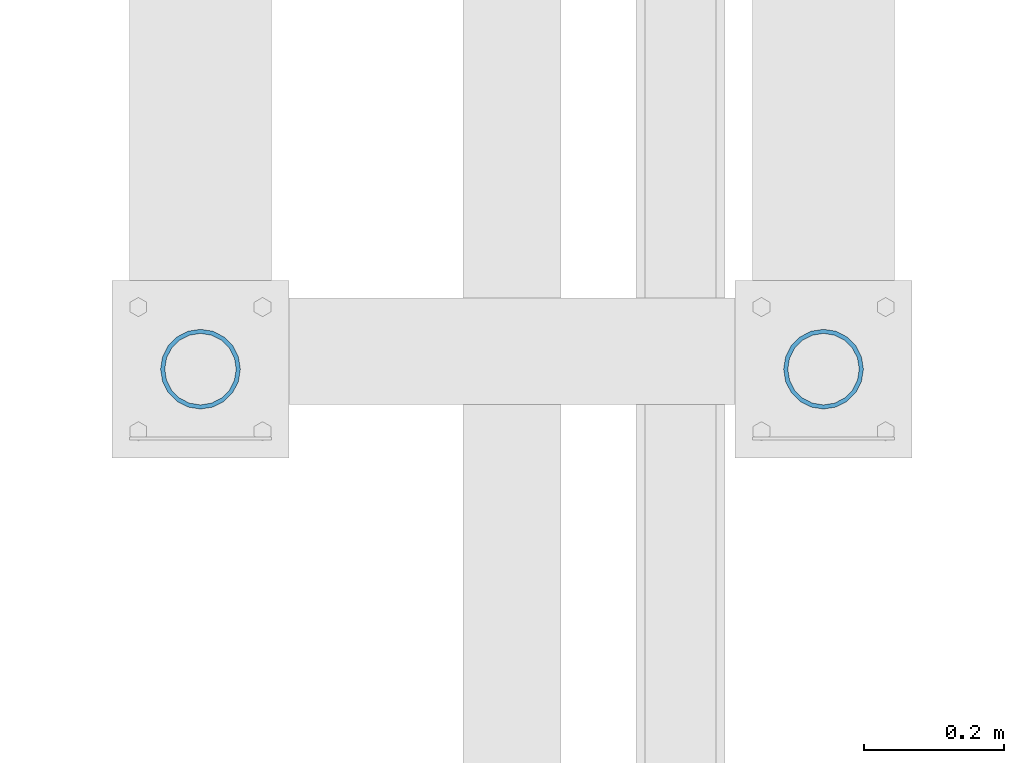
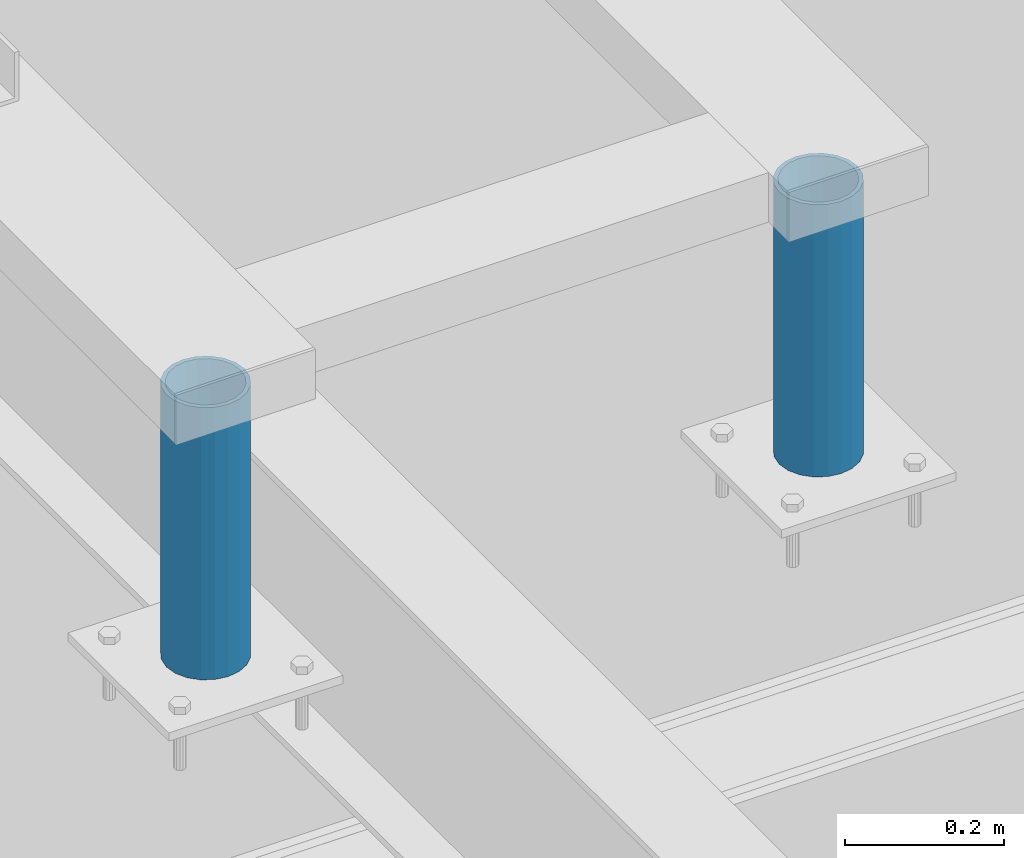
# One storey, part 560 of 1179: 2 columns, 1 element without a shape of its own.
"""IFC2X3 building model written with IfcOpenShell, lengths in millimetres."""

from ifc_helpers import new_model, si_unit, frame, origin_with_axes, place, context, subcontext, project, spatial, faceted_brep, material, type_object, element, aggregate, save


model = new_model("IFC2X3")

# Units and contexts
model_context = context("Model", 3, precision=1e-05, world=origin_with_axes())
body_context = subcontext(model_context, "Body", "Model", "MODEL_VIEW")
ifc_project = project(units=[si_unit("LENGTHUNIT", "METRE", prefix="MILLI"), si_unit("AREAUNIT", "SQUARE_METRE"), si_unit("VOLUMEUNIT", "CUBIC_METRE"), si_unit("MASSUNIT", "GRAM", prefix="KILO"), si_unit("TIMEUNIT", "SECOND"), si_unit("PLANEANGLEUNIT", "RADIAN"), si_unit("SOLIDANGLEUNIT", "STERADIAN"), si_unit("THERMODYNAMICTEMPERATUREUNIT", "DEGREE_CELSIUS"), si_unit("LUMINOUSINTENSITYUNIT", "LUMEN")], contexts=[model_context])

# Site, building, storey
site_placement = place(None, origin_with_axes())
site = spatial("IfcSite", under=ifc_project, at=site_placement, CompositionType="ELEMENT")
building_placement = place(site_placement, origin_with_axes())
building = spatial("IfcBuilding", under=site, at=building_placement, Name="Undefined", CompositionType="ELEMENT")
storey_placement = place(building_placement, origin_with_axes())
storey = spatial("IfcBuildingStorey", under=building, at=storey_placement, Name="Undefined", CompositionType="ELEMENT", Elevation=0.0)

# Assembly, columns
assembly_placement = place(storey_placement, origin_with_axes())
assembly = element("IfcElementAssembly", 1, at=assembly_placement, inside=storey, Name="FRAME", AssemblyPlace="NOTDEFINED", PredefinedType="RIGID_FRAME")
ifc_material = material()
column_type = type_object("IfcColumnType", Name="PIPE4SCH40", PredefinedType="NOTDEFINED")
column_1_placement = place(assembly_placement, frame((20575.5875, 36227.6225542222, 13265.15), z_axis=(0.0, 1.0, 0.0), x_axis=(0.0, 0.0, 1.0)))
column_1 = element("IfcColumn", 2, at=column_1_placement, type_object=column_type, material=ifc_material, Name="COLUMN", ObjectType="PIPE4SCH40", context=body_context, shape_type="Brep", body=[
    faceted_brep([(0.0, -51.1301999999996, 0.0), (0.0, -48.6277098894752, 15.8001007257917), (419.099999999999, -48.6277098894752, 15.8001007257917), (419.099999999999, -51.1301999999996, 0.0), (0.0, -41.3652007257915, 30.0535775067619), (419.099999999999, -41.3652007257915, 30.0535775067619), (0.0, -30.0535775067656, 41.3652007257915), (419.099999999999, -30.0535775067656, 41.3652007257915), (0.0, -15.8001007257917, 48.6277098894716), (419.099999999999, -15.8001007257917, 48.6277098894716), (0.0, 0.0, 51.1301999999996), (419.099999999999, 0.0, 51.1301999999996), (0.0, 15.8001007257917, 48.6277098894716), (419.099999999999, 15.8001007257917, 48.6277098894716), (0.0, 30.0535775067656, 41.3652007257915), (419.099999999999, 30.0535775067656, 41.3652007257915), (0.0, 41.3652007257915, 30.0535775067619), (419.099999999999, 41.3652007257915, 30.0535775067619), (0.0, 48.6277098894752, 15.8001007257917), (419.099999999999, 48.6277098894752, 15.8001007257917), (0.0, 51.1301999999996, 0.0), (419.099999999999, 51.1301999999996, 0.0), (0.0, 48.6277098894752, -15.8001007257917), (419.099999999999, 48.6277098894752, -15.8001007257917), (0.0, 41.3652007257915, -30.0535775067619), (419.099999999999, 41.3652007257915, -30.0535775067619), (0.0, 30.0535775067656, -41.3652007257915), (419.099999999999, 30.0535775067656, -41.3652007257915), (0.0, 15.8001007257917, -48.6277098894716), (419.099999999999, 15.8001007257917, -48.6277098894716), (0.0, 0.0, -51.1301999999996), (419.099999999999, 0.0, -51.1301999999996), (0.0, -15.8001007257917, -48.6277098894716), (419.099999999999, -15.8001007257917, -48.6277098894716), (0.0, -30.0535775067656, -41.3652007257915), (419.099999999999, -30.0535775067656, -41.3652007257915), (0.0, -41.3652007257915, -30.0535775067619), (419.099999999999, -41.3652007257915, -30.0535775067619), (0.0, -48.6277098894752, -15.8001007257917), (419.099999999999, -48.6277098894752, -15.8001007257917), (0.0, -57.1500000000015, 0.0), (0.0, -54.3528799062697, -17.6603212285263), (419.099999999999, -54.3528799062697, -17.6603212285263), (419.099999999999, -57.1500000000015, 0.0), (0.0, -46.235321228527, -33.5919271685125), (419.099999999999, -46.235321228527, -33.5919271685125), (0.0, -33.5919271685161, -46.2353212285307), (419.099999999999, -33.5919271685161, -46.2353212285307), (0.0, -17.6603212285299, -54.3528799062697), (419.099999999999, -17.6603212285299, -54.3528799062697), (0.0, 0.0, -57.1500000000015), (419.099999999999, 0.0, -57.1500000000015), (0.0, 17.6603212285299, -54.3528799062697), (419.099999999999, 17.6603212285299, -54.3528799062697), (0.0, 33.5919271685161, -46.2353212285307), (419.099999999999, 33.5919271685161, -46.2353212285307), (0.0, 46.235321228527, -33.5919271685125), (419.099999999999, 46.235321228527, -33.5919271685125), (0.0, 54.3528799062697, -17.6603212285263), (419.099999999999, 54.3528799062697, -17.6603212285263), (0.0, 57.1500000000015, 0.0), (419.099999999999, 57.1500000000015, 0.0), (0.0, 54.3528799062697, 17.6603212285263), (419.099999999999, 54.3528799062697, 17.6603212285263), (0.0, 46.235321228527, 33.5919271685125), (419.099999999999, 46.235321228527, 33.5919271685125), (0.0, 33.5919271685161, 46.2353212285307), (419.099999999999, 33.5919271685161, 46.2353212285307), (0.0, 17.6603212285299, 54.3528799062697), (419.099999999999, 17.6603212285299, 54.3528799062697), (0.0, 0.0, 57.1500000000015), (419.099999999999, 0.0, 57.1500000000015), (0.0, -17.6603212285299, 54.3528799062697), (419.099999999999, -17.6603212285299, 54.3528799062697), (0.0, -33.5919271685161, 46.2353212285307), (419.099999999999, -33.5919271685161, 46.2353212285307), (0.0, -46.235321228527, 33.5919271685125), (419.099999999999, -46.235321228527, 33.5919271685125), (0.0, -54.3528799062697, 17.6603212285263), (419.099999999999, -54.3528799062697, 17.6603212285263)], [[[0, 1, 2, 3]], [[1, 4, 5, 2]], [[4, 6, 7, 5]], [[6, 8, 9, 7]], [[8, 10, 11, 9]], [[10, 12, 13, 11]], [[12, 14, 15, 13]], [[14, 16, 17, 15]], [[16, 18, 19, 17]], [[18, 20, 21, 19]], [[20, 22, 23, 21]], [[22, 24, 25, 23]], [[24, 26, 27, 25]], [[26, 28, 29, 27]], [[28, 30, 31, 29]], [[30, 32, 33, 31]], [[32, 34, 35, 33]], [[34, 36, 37, 35]], [[36, 38, 39, 37]], [[38, 0, 3, 39]], [[40, 41, 42, 43]], [[41, 44, 45, 42]], [[44, 46, 47, 45]], [[46, 48, 49, 47]], [[48, 50, 51, 49]], [[50, 52, 53, 51]], [[52, 54, 55, 53]], [[54, 56, 57, 55]], [[56, 58, 59, 57]], [[58, 60, 61, 59]], [[60, 62, 63, 61]], [[62, 64, 65, 63]], [[64, 66, 67, 65]], [[66, 68, 69, 67]], [[68, 70, 71, 69]], [[70, 72, 73, 71]], [[72, 74, 75, 73]], [[74, 76, 77, 75]], [[76, 78, 79, 77]], [[78, 40, 43, 79]], [[45, 47, 49, 51, 53, 55, 57, 59, 61, 63, 65, 67, 69, 71, 73, 75, 77, 79, 43, 42], [5, 7, 9, 11, 13, 15, 17, 19, 21, 23, 25, 27, 29, 31, 33, 35, 37, 39, 3, 2]], [[78, 76, 74, 72, 70, 68, 66, 64, 62, 60, 58, 56, 54, 52, 50, 48, 46, 44, 41, 40], [38, 36, 34, 32, 30, 28, 26, 24, 22, 20, 18, 16, 14, 12, 10, 8, 6, 4, 1, 0]]]),
])
column_2_placement = place(assembly_placement, frame((19683.4125, 36227.6225542222, 13265.15), z_axis=(0.0, 1.0, 0.0), x_axis=(0.0, 0.0, 1.0)))
column_2 = element("IfcColumn", 3, at=column_2_placement, type_object=column_type, material=ifc_material, Name="COLUMN", ObjectType="PIPE4SCH40", context=body_context, shape_type="Brep", body=[
    faceted_brep([(0.0, -51.1301999999996, 0.0), (0.0, -48.6277098894752, 15.8001007257917), (419.099999999999, -48.6277098894752, 15.8001007257917), (419.099999999999, -51.1301999999996, 0.0), (0.0, -41.3652007257915, 30.0535775067619), (419.099999999999, -41.3652007257915, 30.0535775067619), (0.0, -30.0535775067656, 41.3652007257915), (419.099999999999, -30.0535775067656, 41.3652007257915), (0.0, -15.8001007257917, 48.6277098894716), (419.099999999999, -15.8001007257917, 48.6277098894716), (0.0, 0.0, 51.1301999999996), (419.099999999999, 0.0, 51.1301999999996), (0.0, 15.8001007257917, 48.6277098894716), (419.099999999999, 15.8001007257917, 48.6277098894716), (0.0, 30.0535775067656, 41.3652007257915), (419.099999999999, 30.0535775067656, 41.3652007257915), (0.0, 41.3652007257915, 30.0535775067619), (419.099999999999, 41.3652007257915, 30.0535775067619), (0.0, 48.6277098894752, 15.8001007257917), (419.099999999999, 48.6277098894752, 15.8001007257917), (0.0, 51.1301999999996, 0.0), (419.099999999999, 51.1301999999996, 0.0), (0.0, 48.6277098894752, -15.8001007257917), (419.099999999999, 48.6277098894752, -15.8001007257917), (0.0, 41.3652007257915, -30.0535775067619), (419.099999999999, 41.3652007257915, -30.0535775067619), (0.0, 30.0535775067656, -41.3652007257915), (419.099999999999, 30.0535775067656, -41.3652007257915), (0.0, 15.8001007257917, -48.6277098894716), (419.099999999999, 15.8001007257917, -48.6277098894716), (0.0, 0.0, -51.1301999999996), (419.099999999999, 0.0, -51.1301999999996), (0.0, -15.8001007257917, -48.6277098894716), (419.099999999999, -15.8001007257917, -48.6277098894716), (0.0, -30.0535775067656, -41.3652007257915), (419.099999999999, -30.0535775067656, -41.3652007257915), (0.0, -41.3652007257915, -30.0535775067619), (419.099999999999, -41.3652007257915, -30.0535775067619), (0.0, -48.6277098894752, -15.8001007257917), (419.099999999999, -48.6277098894752, -15.8001007257917), (0.0, -57.1500000000015, 0.0), (0.0, -54.3528799062697, -17.6603212285263), (419.099999999999, -54.3528799062697, -17.6603212285263), (419.099999999999, -57.1500000000015, 0.0), (0.0, -46.235321228527, -33.5919271685125), (419.099999999999, -46.235321228527, -33.5919271685125), (0.0, -33.5919271685161, -46.2353212285307), (419.099999999999, -33.5919271685161, -46.2353212285307), (0.0, -17.6603212285299, -54.3528799062697), (419.099999999999, -17.6603212285299, -54.3528799062697), (0.0, 0.0, -57.1500000000015), (419.099999999999, 0.0, -57.1500000000015), (0.0, 17.6603212285299, -54.3528799062697), (419.099999999999, 17.6603212285299, -54.3528799062697), (0.0, 33.5919271685161, -46.2353212285307), (419.099999999999, 33.5919271685161, -46.2353212285307), (0.0, 46.235321228527, -33.5919271685125), (419.099999999999, 46.235321228527, -33.5919271685125), (0.0, 54.3528799062697, -17.6603212285263), (419.099999999999, 54.3528799062697, -17.6603212285263), (0.0, 57.1500000000015, 0.0), (419.099999999999, 57.1500000000015, 0.0), (0.0, 54.3528799062697, 17.6603212285263), (419.099999999999, 54.3528799062697, 17.6603212285263), (0.0, 46.235321228527, 33.5919271685125), (419.099999999999, 46.235321228527, 33.5919271685125), (0.0, 33.5919271685161, 46.2353212285307), (419.099999999999, 33.5919271685161, 46.2353212285307), (0.0, 17.6603212285299, 54.3528799062697), (419.099999999999, 17.6603212285299, 54.3528799062697), (0.0, 0.0, 57.1500000000015), (419.099999999999, 0.0, 57.1500000000015), (0.0, -17.6603212285299, 54.3528799062697), (419.099999999999, -17.6603212285299, 54.3528799062697), (0.0, -33.5919271685161, 46.2353212285307), (419.099999999999, -33.5919271685161, 46.2353212285307), (0.0, -46.235321228527, 33.5919271685125), (419.099999999999, -46.235321228527, 33.5919271685125), (0.0, -54.3528799062697, 17.6603212285263), (419.099999999999, -54.3528799062697, 17.6603212285263)], [[[0, 1, 2, 3]], [[1, 4, 5, 2]], [[4, 6, 7, 5]], [[6, 8, 9, 7]], [[8, 10, 11, 9]], [[10, 12, 13, 11]], [[12, 14, 15, 13]], [[14, 16, 17, 15]], [[16, 18, 19, 17]], [[18, 20, 21, 19]], [[20, 22, 23, 21]], [[22, 24, 25, 23]], [[24, 26, 27, 25]], [[26, 28, 29, 27]], [[28, 30, 31, 29]], [[30, 32, 33, 31]], [[32, 34, 35, 33]], [[34, 36, 37, 35]], [[36, 38, 39, 37]], [[38, 0, 3, 39]], [[40, 41, 42, 43]], [[41, 44, 45, 42]], [[44, 46, 47, 45]], [[46, 48, 49, 47]], [[48, 50, 51, 49]], [[50, 52, 53, 51]], [[52, 54, 55, 53]], [[54, 56, 57, 55]], [[56, 58, 59, 57]], [[58, 60, 61, 59]], [[60, 62, 63, 61]], [[62, 64, 65, 63]], [[64, 66, 67, 65]], [[66, 68, 69, 67]], [[68, 70, 71, 69]], [[70, 72, 73, 71]], [[72, 74, 75, 73]], [[74, 76, 77, 75]], [[76, 78, 79, 77]], [[78, 40, 43, 79]], [[45, 47, 49, 51, 53, 55, 57, 59, 61, 63, 65, 67, 69, 71, 73, 75, 77, 79, 43, 42], [5, 7, 9, 11, 13, 15, 17, 19, 21, 23, 25, 27, 29, 31, 33, 35, 37, 39, 3, 2]], [[78, 76, 74, 72, 70, 68, 66, 64, 62, 60, 58, 56, 54, 52, 50, 48, 46, 44, 41, 40], [38, 36, 34, 32, 30, 28, 26, 24, 22, 20, 18, 16, 14, 12, 10, 8, 6, 4, 1, 0]]]),
])
aggregate(assembly, [column_1, column_2])

save(model, "model.ifc")
